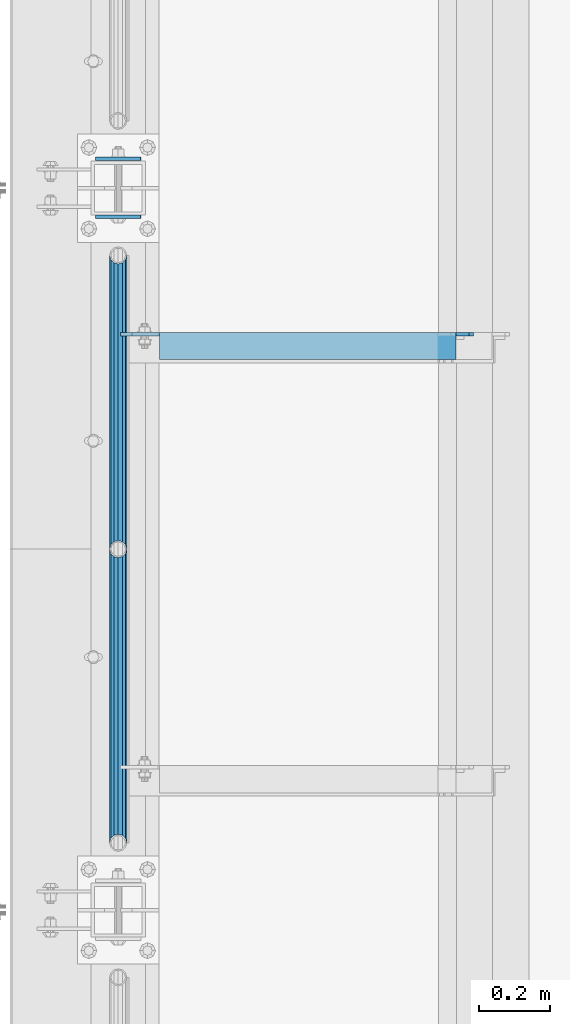
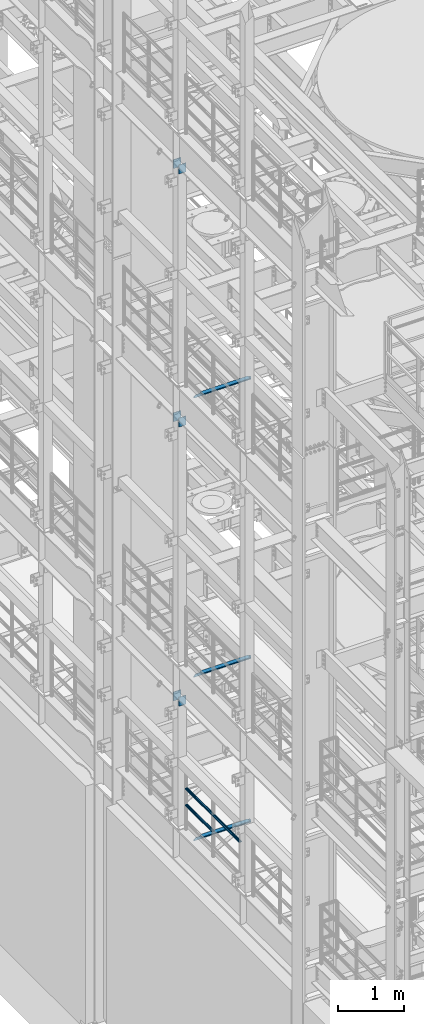
# One storey, part 1229 of 1876: 12 beams, 7 elements without a shape of their own.
"""IFC2X3 building model written with IfcOpenShell, lengths in millimetres."""

from ifc_helpers import new_model, si_unit, frame, origin_with_axes, place, context, subcontext, project, spatial, faceted_brep, material, type_object, element, aggregate, save


model = new_model("IFC2X3")

# Units and contexts
model_context = context("Model", 3, precision=1e-05, world=origin_with_axes())
body_context = subcontext(model_context, "Body", "Model", "MODEL_VIEW")
ifc_project = project(units=[si_unit("LENGTHUNIT", "METRE", prefix="MILLI"), si_unit("AREAUNIT", "SQUARE_METRE"), si_unit("VOLUMEUNIT", "CUBIC_METRE"), si_unit("MASSUNIT", "GRAM", prefix="KILO"), si_unit("TIMEUNIT", "SECOND"), si_unit("PLANEANGLEUNIT", "RADIAN"), si_unit("SOLIDANGLEUNIT", "STERADIAN"), si_unit("THERMODYNAMICTEMPERATUREUNIT", "DEGREE_CELSIUS"), si_unit("LUMINOUSINTENSITYUNIT", "LUMEN")], contexts=[model_context])

# Site, building, storey
site_placement = place(None, origin_with_axes())
site = spatial("IfcSite", under=ifc_project, at=site_placement, CompositionType="ELEMENT")
building_placement = place(site_placement, origin_with_axes())
building = spatial("IfcBuilding", under=site, at=building_placement, Name="Undefined", CompositionType="ELEMENT")
storey_placement = place(building_placement, origin_with_axes())
storey = spatial("IfcBuildingStorey", under=building, at=storey_placement, Name="Undefined", CompositionType="ELEMENT", Elevation=0.0)

# Assembly, beams
assembly_1_placement = place(storey_placement, origin_with_axes())
assembly_1 = element("IfcElementAssembly", 1, at=assembly_1_placement, inside=storey, Name="RAIL", AssemblyPlace="NOTDEFINED", PredefinedType="RIGID_FRAME")
ifc_material_1 = material()
beam_type_1 = type_object("IfcBeamType", Name="PIPE1-1/2SCH40", PredefinedType="NOTDEFINED")
beam_1_placement = place(assembly_1_placement, frame((-1.81898940354586e-12, -1524.0, 5597.525), z_axis=(0.0, 0.0, -1.0), x_axis=(0.0, 1.0, 0.0)))
beam_1 = element("IfcBeam", 2, at=beam_1_placement, type_object=beam_type_1, material=ifc_material_1, Name="RAIL", ObjectType="PIPE1-1/2SCH40", context=body_context, shape_type="Brep", body=[
    faceted_brep([(0.0, 24.1299999999992, 0.0), (12.0650000000064, 20.8971929933177, -12.0649999999987), (12.0650000000064, 20.8971929933177, 12.0649999999987), (12.0650000000064, -20.8971929933177, 12.0649999999987), (12.0650000000064, -20.8971929933177, -12.0649999999987), (0.0, -24.1299999999992, 0.0), (20.8971929933249, -12.0650000000005, 20.8971929933177), (20.8971929933249, -12.0650000000005, 15.8661214311796), (15.2545715621445, -17.7076214311801, 10.2235000000001), (12.5151929933249, -20.4470000000001, 0.0), (15.2545715621445, -17.7076214311801, -10.2235000000001), (20.8971929933249, -12.0650000000005, -15.8661214311796), (20.8971929933249, -12.0650000000005, -20.8971929933177), (24.1300000000063, 0.0, -20.4470000000001), (24.1300000000063, 0.0, -24.130000000001), (21.3906214311868, -10.2235000000001, -17.7076214311819), (21.3906214311868, 10.2235000000001, -17.7076214311819), (20.8971929933249, 12.0650000000005, -15.8661214311796), (20.8971929933249, 12.0650000000005, -20.8971929933177), (15.2545715621445, 17.7076214311801, -10.2235000000001), (12.5151929933249, 20.4470000000001, 0.0), (15.2545715621445, 17.7076214311801, 10.2235000000001), (20.8971929933249, 12.0650000000005, 15.8661214311796), (20.8971929933249, 12.0650000000005, 20.8971929933177), (21.3906214311868, 10.2235000000001, 17.7076214311819), (24.1300000000064, 0.0, 20.4470000000001), (24.1300000000064, 0.0, 24.130000000001), (21.3906214311868, -10.2235000000001, 17.7076214311819), (826.77, 24.1300000000001, 0.0), (814.705, 20.8971929933186, -12.0649999999987), (805.872807006681, 12.0649999999996, -20.8971929933177), (826.77, -24.1300000000001, 0.0), (814.705, -20.8971929933186, -12.0649999999987), (814.705, -20.8971929933186, 12.0649999999987), (805.872807006681, -12.0649999999996, 20.8971929933177), (805.872807006681, -12.0649999999996, -20.8971929933177), (802.640000000001, 0.0, -24.130000000001), (805.379378568819, 10.2235000000001, -17.7076214311819), (802.640000000001, 0.0, -20.4470000000001), (805.872807006683, 12.0649999999996, -15.8661214311796), (805.872807006683, -12.0649999999996, -15.8661214311796), (805.379378568819, -10.2235000000001, -17.7076214311819), (811.515428437862, -17.7076214311801, -10.2235000000001), (814.254807006682, -20.4470000000001, 0.0), (811.515428437862, -17.7076214311801, 10.2235000000001), (805.872807006683, -12.0649999999996, 15.8661214311796), (805.379378568819, -10.2235000000001, 17.7076214311819), (802.640000000001, 0.0, 20.4470000000001), (802.640000000001, 0.0, 24.130000000001), (805.872807006681, 12.0649999999996, 20.8971929933177), (814.705, 20.8971929933186, 12.0649999999987), (805.872807006683, 12.0649999999996, 15.8661214311796), (811.515428437862, 17.7076214311801, 10.2235000000001), (814.254807006682, 20.4470000000001, 0.0), (811.515428437862, 17.7076214311801, -10.2235000000001), (805.379378568819, 10.2235000000001, 17.7076214311819)], [[[0, 1, 2]], [[3, 4, 5]], [[6, 7, 8, 9, 10, 11, 12, 4, 3]], [[13, 14, 12, 11, 15]], [[16, 17, 18, 14, 13]], [[2, 1, 18, 17, 19, 20, 21, 22, 23]], [[23, 22, 24, 25, 26]], [[26, 25, 27, 7, 6]], [[1, 0, 28, 29]], [[18, 1, 29, 30]], [[31, 32, 33]], [[6, 3, 33, 34]], [[3, 5, 31, 33]], [[5, 4, 32, 31]], [[4, 12, 35, 32]], [[12, 14, 36, 35]], [[14, 18, 30, 36]], [[37, 38, 36, 30, 39]], [[40, 35, 36, 38, 41]], [[33, 32, 35, 40, 42, 43, 44, 45, 34]], [[34, 45, 46, 47, 48]], [[26, 6, 34, 48]], [[2, 23, 49, 50]], [[23, 26, 48, 49]], [[0, 2, 50, 28]], [[28, 50, 29]], [[49, 51, 52, 53, 54, 39, 30, 29, 50]], [[48, 47, 55, 51, 49]], [[25, 24, 55, 47]], [[55, 24, 22, 21, 52, 51]], [[21, 20, 53, 52]], [[20, 19, 54, 53]], [[19, 17, 16, 37, 39, 54]], [[16, 13, 38, 37]], [[13, 15, 41, 38]], [[41, 15, 11, 10, 42, 40]], [[10, 9, 43, 42]], [[9, 8, 44, 43]], [[8, 7, 27, 46, 45, 44]], [[27, 25, 47, 46]]]),
])
beam_2_placement = place(assembly_1_placement, frame((-1.81898940354586e-12, -2350.77, 5902.325), z_axis=(0.0, 0.0, -1.0), x_axis=(0.0, 1.0, 0.0)))
beam_2 = element("IfcBeam", 3, at=beam_2_placement, type_object=beam_type_1, material=ifc_material_1, Name="RAIL", ObjectType="PIPE1-1/2SCH40", context=body_context, shape_type="Brep", body=[
    faceted_brep([(0.0, 24.1299999999992, 0.0), (12.0650000000064, 20.8971929933177, -12.0649999999987), (12.0650000000064, 20.8971929933177, 12.0649999999987), (12.0650000000064, -20.8971929933177, 12.0649999999987), (12.0650000000064, -20.8971929933177, -12.0649999999987), (0.0, -24.1299999999992, 0.0), (20.8971929933249, -12.0650000000005, 20.8971929933177), (20.8971929933249, -12.0650000000005, 15.8661214311796), (15.2545715621445, -17.7076214311801, 10.2235000000001), (12.5151929933249, -20.4470000000001, 0.0), (15.2545715621445, -17.7076214311801, -10.2235000000001), (20.8971929933249, -12.0650000000005, -15.8661214311796), (20.8971929933249, -12.0650000000005, -20.8971929933177), (24.1300000000063, 0.0, -20.4470000000001), (24.1300000000063, 0.0, -24.130000000001), (21.3906214311868, -10.2235000000001, -17.7076214311819), (21.3906214311868, 10.2235000000001, -17.7076214311819), (20.8971929933249, 12.0650000000005, -15.8661214311796), (20.8971929933249, 12.0650000000005, -20.8971929933177), (15.2545715621445, 17.7076214311801, -10.2235000000001), (12.5151929933249, 20.4470000000001, 0.0), (15.2545715621445, 17.7076214311801, 10.2235000000001), (20.8971929933249, 12.0650000000005, 15.8661214311796), (20.8971929933249, 12.0650000000005, 20.8971929933177), (21.3906214311868, 10.2235000000001, 17.7076214311819), (24.1300000000064, 0.0, 20.4470000000001), (24.1300000000064, 0.0, 24.130000000001), (21.3906214311868, -10.2235000000001, 17.7076214311819), (826.77, 24.1300000000001, 0.0), (814.705, 20.8971929933186, -12.0649999999987), (805.872807006681, 12.0649999999996, -20.8971929933177), (826.77, -24.1300000000001, 0.0), (814.705, -20.8971929933186, -12.0649999999987), (814.705, -20.8971929933186, 12.0649999999987), (805.872807006681, -12.0649999999996, 20.8971929933177), (805.872807006681, -12.0649999999996, -20.8971929933177), (802.640000000001, 0.0, -24.130000000001), (805.379378568819, 10.2235000000001, -17.7076214311819), (802.640000000001, 0.0, -20.4470000000001), (805.872807006683, 12.0649999999996, -15.8661214311796), (805.872807006683, -12.0649999999996, -15.8661214311796), (805.379378568819, -10.2235000000001, -17.7076214311819), (811.515428437862, -17.7076214311801, -10.2235000000001), (814.254807006682, -20.4470000000001, 0.0), (811.515428437862, -17.7076214311801, 10.2235000000001), (805.872807006683, -12.0649999999996, 15.8661214311796), (805.379378568819, -10.2235000000001, 17.7076214311819), (802.640000000001, 0.0, 20.4470000000001), (802.640000000001, 0.0, 24.130000000001), (805.872807006681, 12.0649999999996, 20.8971929933177), (814.705, 20.8971929933186, 12.0649999999987), (805.872807006683, 12.0649999999996, 15.8661214311796), (811.515428437862, 17.7076214311801, 10.2235000000001), (814.254807006682, 20.4470000000001, 0.0), (811.515428437862, 17.7076214311801, -10.2235000000001), (805.379378568819, 10.2235000000001, 17.7076214311819)], [[[0, 1, 2]], [[3, 4, 5]], [[6, 7, 8, 9, 10, 11, 12, 4, 3]], [[13, 14, 12, 11, 15]], [[16, 17, 18, 14, 13]], [[2, 1, 18, 17, 19, 20, 21, 22, 23]], [[23, 22, 24, 25, 26]], [[26, 25, 27, 7, 6]], [[1, 0, 28, 29]], [[18, 1, 29, 30]], [[31, 32, 33]], [[6, 3, 33, 34]], [[3, 5, 31, 33]], [[5, 4, 32, 31]], [[4, 12, 35, 32]], [[12, 14, 36, 35]], [[14, 18, 30, 36]], [[37, 38, 36, 30, 39]], [[40, 35, 36, 38, 41]], [[33, 32, 35, 40, 42, 43, 44, 45, 34]], [[34, 45, 46, 47, 48]], [[26, 6, 34, 48]], [[2, 23, 49, 50]], [[23, 26, 48, 49]], [[0, 2, 50, 28]], [[28, 50, 29]], [[49, 51, 52, 53, 54, 39, 30, 29, 50]], [[48, 47, 55, 51, 49]], [[25, 24, 55, 47]], [[55, 24, 22, 21, 52, 51]], [[21, 20, 53, 52]], [[20, 19, 54, 53]], [[19, 17, 16, 37, 39, 54]], [[16, 13, 38, 37]], [[13, 15, 41, 38]], [[41, 15, 11, 10, 42, 40]], [[10, 9, 43, 42]], [[9, 8, 44, 43]], [[8, 7, 27, 46, 45, 44]], [[27, 25, 47, 46]]]),
])
beam_3_placement = place(assembly_1_placement, frame((-1.81898940354586e-12, -1524.0, 5902.325), z_axis=(0.0, 0.0, -1.0), x_axis=(0.0, 1.0, 0.0)))
beam_3 = element("IfcBeam", 4, at=beam_3_placement, type_object=beam_type_1, material=ifc_material_1, Name="RAIL", ObjectType="PIPE1-1/2SCH40", context=body_context, shape_type="Brep", body=[
    faceted_brep([(0.0, 24.1299999999992, 0.0), (12.0650000000064, 20.8971929933177, -12.0649999999987), (12.0650000000064, 20.8971929933177, 12.0649999999987), (12.0650000000064, -20.8971929933177, 12.0649999999987), (12.0650000000064, -20.8971929933177, -12.0649999999987), (0.0, -24.1299999999992, 0.0), (20.8971929933249, -12.0650000000005, 20.8971929933177), (20.8971929933249, -12.0650000000005, 15.8661214311796), (15.2545715621445, -17.7076214311801, 10.2235000000001), (12.5151929933249, -20.4470000000001, 0.0), (15.2545715621445, -17.7076214311801, -10.2235000000001), (20.8971929933249, -12.0650000000005, -15.8661214311796), (20.8971929933249, -12.0650000000005, -20.8971929933177), (24.1300000000063, 0.0, -20.4470000000001), (24.1300000000063, 0.0, -24.130000000001), (21.3906214311868, -10.2235000000001, -17.7076214311819), (21.3906214311868, 10.2235000000001, -17.7076214311819), (20.8971929933249, 12.0650000000005, -15.8661214311796), (20.8971929933249, 12.0650000000005, -20.8971929933177), (15.2545715621445, 17.7076214311801, -10.2235000000001), (12.5151929933249, 20.4470000000001, 0.0), (15.2545715621445, 17.7076214311801, 10.2235000000001), (20.8971929933249, 12.0650000000005, 15.8661214311796), (20.8971929933249, 12.0650000000005, 20.8971929933177), (21.3906214311868, 10.2235000000001, 17.7076214311819), (24.1300000000064, 0.0, 20.4470000000001), (24.1300000000064, 0.0, 24.130000000001), (21.3906214311868, -10.2235000000001, 17.7076214311819), (826.77, 24.1300000000001, 0.0), (814.705, 20.8971929933186, -12.0649999999987), (805.872807006681, 12.0649999999996, -20.8971929933177), (826.77, -24.1300000000001, 0.0), (814.705, -20.8971929933186, -12.0649999999987), (814.705, -20.8971929933186, 12.0649999999987), (805.872807006681, -12.0649999999996, 20.8971929933177), (805.872807006681, -12.0649999999996, -20.8971929933177), (802.640000000001, 0.0, -24.130000000001), (805.379378568819, 10.2235000000001, -17.7076214311819), (802.640000000001, 0.0, -20.4470000000001), (805.872807006683, 12.0649999999996, -15.8661214311796), (805.872807006683, -12.0649999999996, -15.8661214311796), (805.379378568819, -10.2235000000001, -17.7076214311819), (811.515428437862, -17.7076214311801, -10.2235000000001), (814.254807006682, -20.4470000000001, 0.0), (811.515428437862, -17.7076214311801, 10.2235000000001), (805.872807006683, -12.0649999999996, 15.8661214311796), (805.379378568819, -10.2235000000001, 17.7076214311819), (802.640000000001, 0.0, 20.4470000000001), (802.640000000001, 0.0, 24.130000000001), (805.872807006681, 12.0649999999996, 20.8971929933177), (814.705, 20.8971929933186, 12.0649999999987), (805.872807006683, 12.0649999999996, 15.8661214311796), (811.515428437862, 17.7076214311801, 10.2235000000001), (814.254807006682, 20.4470000000001, 0.0), (811.515428437862, 17.7076214311801, -10.2235000000001), (805.379378568819, 10.2235000000001, 17.7076214311819)], [[[0, 1, 2]], [[3, 4, 5]], [[6, 7, 8, 9, 10, 11, 12, 4, 3]], [[13, 14, 12, 11, 15]], [[16, 17, 18, 14, 13]], [[2, 1, 18, 17, 19, 20, 21, 22, 23]], [[23, 22, 24, 25, 26]], [[26, 25, 27, 7, 6]], [[1, 0, 28, 29]], [[18, 1, 29, 30]], [[31, 32, 33]], [[6, 3, 33, 34]], [[3, 5, 31, 33]], [[5, 4, 32, 31]], [[4, 12, 35, 32]], [[12, 14, 36, 35]], [[14, 18, 30, 36]], [[37, 38, 36, 30, 39]], [[40, 35, 36, 38, 41]], [[33, 32, 35, 40, 42, 43, 44, 45, 34]], [[34, 45, 46, 47, 48]], [[26, 6, 34, 48]], [[2, 23, 49, 50]], [[23, 26, 48, 49]], [[0, 2, 50, 28]], [[28, 50, 29]], [[49, 51, 52, 53, 54, 39, 30, 29, 50]], [[48, 47, 55, 51, 49]], [[25, 24, 55, 47]], [[55, 24, 22, 21, 52, 51]], [[21, 20, 53, 52]], [[20, 19, 54, 53]], [[19, 17, 16, 37, 39, 54]], [[16, 13, 38, 37]], [[13, 15, 41, 38]], [[41, 15, 11, 10, 42, 40]], [[10, 9, 43, 42]], [[9, 8, 44, 43]], [[8, 7, 27, 46, 45, 44]], [[27, 25, 47, 46]]]),
])
aggregate(assembly_1, [beam_1, beam_2, beam_3])

assembly_2_placement = place(storey_placement, origin_with_axes())
assembly_2 = element("IfcElementAssembly", 5, at=assembly_2_placement, inside=storey, Name="BEAM", AssemblyPlace="NOTDEFINED", PredefinedType="RIGID_FRAME")
ifc_material_2 = material(Name="STEEL/A36")
beam_type_2 = type_object("IfcBeamType", PredefinedType="NOTDEFINED")
beam_4_placement = place(assembly_2_placement, frame((-63.6296757345187, -425.45, 7448.54714244377), z_axis=(5.59490000219896e-05, 0.0, -0.999999998434855), x_axis=(0.999999998434855, 0.0, 5.59490000219868e-05)))
beam_4 = element("IfcBeam", 6, at=beam_4_placement, type_object=beam_type_2, material=ifc_material_2, Name="PLATE", context=body_context, shape_type="Brep", body=[
    faceted_brep([(0.0, 4.76249999999982, -82.5499999999993), (0.0, 4.76249999999982, 82.5499999999993), (127.0, 4.76249999999982, 82.5499999999993), (127.0, 4.76249999999982, -82.5499999999993), (0.0, -4.76249999999982, 82.5499999999993), (127.0, -4.76249999999982, 82.5499999999993), (0.0, -4.76249999999982, -82.5499999999993), (127.0, -4.76249999999982, -82.5499999999993)], [[[0, 1, 2, 3]], [[1, 4, 5, 2]], [[4, 6, 7, 5]], [[6, 0, 3, 7]], [[5, 7, 3, 2]], [[6, 4, 1, 0]]]),
])
beam_5_placement = place(assembly_2_placement, frame((-63.6296757345187, -588.9625, 7448.54714244377), z_axis=(5.59490000219896e-05, 0.0, -0.999999998434855), x_axis=(0.999999998434855, 0.0, 5.59490000219868e-05)))
beam_5 = element("IfcBeam", 7, at=beam_5_placement, type_object=beam_type_2, material=ifc_material_2, Name="PLATE", context=body_context, shape_type="Brep", body=[
    faceted_brep([(0.0, 4.76249999999982, -82.5499999999993), (0.0, 4.76249999999982, 82.5499999999993), (127.0, 4.76249999999982, 82.5499999999993), (127.0, 4.76249999999982, -82.5499999999993), (0.0, -4.76249999999982, 82.5499999999993), (127.0, -4.76249999999982, 82.5499999999993), (0.0, -4.76249999999982, -82.5499999999993), (127.0, -4.76249999999982, -82.5499999999993)], [[[0, 1, 2, 3]], [[1, 4, 5, 2]], [[4, 6, 7, 5]], [[6, 0, 3, 7]], [[5, 7, 3, 2]], [[6, 4, 1, 0]]]),
])
aggregate(assembly_2, [beam_4, beam_5])

assembly_3_placement = place(storey_placement, origin_with_axes())
assembly_3 = element("IfcElementAssembly", 8, at=assembly_3_placement, inside=storey, Name="BEAM", AssemblyPlace="NOTDEFINED", PredefinedType="RIGID_FRAME")
beam_6_placement = place(assembly_3_placement, frame((-63.6315195800257, -425.450000000001, 12604.7488224823), z_axis=(2.95459999824743e-05, 0.0, -0.999999999563517), x_axis=(0.999999999563517, 0.0, 2.95459999828704e-05)))
beam_6 = element("IfcBeam", 9, at=beam_6_placement, type_object=beam_type_2, material=ifc_material_2, Name="PLATE", context=body_context, shape_type="Brep", body=[
    faceted_brep([(0.0, 4.76249999999982, -82.5499999999993), (0.0, 4.76249999999982, 82.5499999999993), (127.0, 4.76249999999982, 82.5499999999993), (127.0, 4.76249999999982, -82.5499999999993), (0.0, -4.76249999999982, 82.5499999999993), (127.0, -4.76249999999982, 82.5499999999993), (0.0, -4.76249999999982, -82.5499999999993), (127.0, -4.76249999999982, -82.5499999999993)], [[[0, 1, 2, 3]], [[1, 4, 5, 2]], [[4, 6, 7, 5]], [[6, 0, 3, 7]], [[5, 7, 3, 2]], [[6, 4, 1, 0]]]),
])
beam_7_placement = place(assembly_3_placement, frame((-63.6315195800257, -588.962500000001, 12604.7488224823), z_axis=(2.95459999824743e-05, 0.0, -0.999999999563517), x_axis=(0.999999999563517, 0.0, 2.95459999828704e-05)))
beam_7 = element("IfcBeam", 10, at=beam_7_placement, type_object=beam_type_2, material=ifc_material_2, Name="PLATE", context=body_context, shape_type="Brep", body=[
    faceted_brep([(0.0, 4.76249999999982, -82.5499999999993), (0.0, 4.76249999999982, 82.5499999999993), (127.0, 4.76249999999982, 82.5499999999993), (127.0, 4.76249999999982, -82.5499999999993), (0.0, -4.76249999999982, 82.5499999999993), (127.0, -4.76249999999982, 82.5499999999993), (0.0, -4.76249999999982, -82.5499999999993), (127.0, -4.76249999999982, -82.5499999999993)], [[[0, 1, 2, 3]], [[1, 4, 5, 2]], [[4, 6, 7, 5]], [[6, 0, 3, 7]], [[5, 7, 3, 2]], [[6, 4, 1, 0]]]),
])
aggregate(assembly_3, [beam_6, beam_7])

assembly_4_placement = place(storey_placement, origin_with_axes())
assembly_4 = element("IfcElementAssembly", 11, at=assembly_4_placement, inside=storey, Name="BEAM", AssemblyPlace="NOTDEFINED", PredefinedType="RIGID_FRAME")
beam_8_placement = place(assembly_4_placement, frame((-63.5, -425.450000000001, 17278.35), z_axis=(0.0, 0.0, -1.0), x_axis=(1.0, 0.0, 0.0)))
beam_8 = element("IfcBeam", 12, at=beam_8_placement, type_object=beam_type_2, material=ifc_material_2, Name="PLATE", context=body_context, shape_type="Brep", body=[
    faceted_brep([(0.0, 4.76249999999982, -82.5499999999993), (0.0, 4.76249999999982, 82.5499999999993), (127.0, 4.76249999999982, 82.5499999999993), (127.0, 4.76249999999982, -82.5499999999993), (0.0, -4.76249999999982, 82.5499999999993), (127.0, -4.76249999999982, 82.5499999999993), (0.0, -4.76249999999982, -82.5499999999993), (127.0, -4.76249999999982, -82.5499999999993)], [[[0, 1, 2, 3]], [[1, 4, 5, 2]], [[4, 6, 7, 5]], [[6, 0, 3, 7]], [[5, 7, 3, 2]], [[6, 4, 1, 0]]]),
])
beam_9_placement = place(assembly_4_placement, frame((-63.5, -588.962500000001, 17278.35), z_axis=(0.0, 0.0, -1.0), x_axis=(1.0, 0.0, 0.0)))
beam_9 = element("IfcBeam", 13, at=beam_9_placement, type_object=beam_type_2, material=ifc_material_2, Name="PLATE", context=body_context, shape_type="Brep", body=[
    faceted_brep([(0.0, 4.76249999999982, -82.5499999999993), (0.0, 4.76249999999982, 82.5499999999993), (127.0, 4.76249999999982, 82.5499999999993), (127.0, 4.76249999999982, -82.5499999999993), (0.0, -4.76249999999982, 82.5499999999993), (127.0, -4.76249999999982, 82.5499999999993), (0.0, -4.76249999999982, -82.5499999999993), (127.0, -4.76249999999982, -82.5499999999993)], [[[0, 1, 2, 3]], [[1, 4, 5, 2]], [[4, 6, 7, 5]], [[6, 0, 3, 7]], [[5, 7, 3, 2]], [[6, 4, 1, 0]]]),
])
aggregate(assembly_4, [beam_8, beam_9])

# Assembly, beam
assembly_5_placement = place(storey_placement, origin_with_axes())
assembly_5 = element("IfcElementAssembly", 14, at=assembly_5_placement, inside=storey, Name="ANGLE", AssemblyPlace="NOTDEFINED", PredefinedType="RIGID_FRAME")
beam_type_3 = type_object("IfcBeamType", Name="L3X3X3/8", PredefinedType="NOTDEFINED")
beam_10_placement = place(assembly_5_placement, frame((0.0, -952.500000000001, 8115.3), z_axis=(0.0, -1.0, 0.0), x_axis=(1.0, 0.0, 0.0)))
beam_10 = element("IfcBeam", 15, at=beam_10_placement, type_object=beam_type_3, material=ifc_material_2, Name="ANGLE", ObjectType="L3X3X3/8", context=body_context, shape_type="Brep", body=[
    faceted_brep([(115.886999817316, 28.5750000000007, 38.0999999999999), (115.886999817316, 38.0999999999985, 38.0999999999999), (115.886998826692, 38.0999999999985, -38.0999999999999), (115.88699882669, 12.699999237062, -38.0999999999999), (115.886998950515, 12.699999237062, -28.5749999999998), (115.88699895052, 28.5750000000007, -28.5749999999998), (38.8937432114558, 12.699999237062, -38.0999999999999), (38.8937433352807, 12.699999237062, -28.5749999999998), (7.14374321145577, -19.050000762938, -38.0999999999999), (7.14374333528067, -19.050000762938, -28.5749999999998), (7.1437499954859, -38.0999999999985, -38.0999999999999), (7.1437499954859, -38.0999999999985, -28.5749999999998), (1000.12500242412, 15.8750003814712, -28.5749999999998), (987.425002614851, 28.5749999999998, -28.5749999999998), (950.913000303442, 28.5749999999998, -28.5749999999998), (1000.12500001551, -38.1000000000004, -28.5749999999998), (1000.12500242412, 3.17500152588036, -28.5749999999998), (950.913001170238, 28.5749999999998, 38.0999999999999), (950.913001170238, 38.1000000000004, 38.0999999999999), (950.913000179614, 38.1000000000004, -38.0999999999999), (950.913000366403, 28.5750001907363, -38.0999999999999), (987.425002357675, 28.5750001907363, -38.0999999999999), (1000.12500216694, 15.8750003814712, -38.0999999999999), (1000.12500216694, 3.17500152588036, -38.0999999999999), (1000.12500001551, -38.1000000000004, -38.0999999999999)], [[[0, 1, 2, 3, 4, 5]], [[4, 3, 6, 7]], [[7, 6, 8, 9]], [[8, 10, 11, 9]], [[12, 13, 14, 5, 4, 7, 9, 11, 15, 16]], [[0, 5, 14, 17]], [[1, 0, 17, 18]], [[2, 1, 18, 19]], [[17, 14, 20, 19, 18]], [[13, 21, 20, 14]], [[12, 22, 21, 13]], [[16, 23, 22, 12]], [[10, 8, 6, 3, 2, 19, 20, 21, 22, 23, 24]], [[11, 10, 24, 15]], [[23, 16, 15, 24]]]),
])
aggregate(assembly_5, [beam_10])

assembly_6_placement = place(storey_placement, origin_with_axes())
assembly_6 = element("IfcElementAssembly", 16, at=assembly_6_placement, inside=storey, Name="ANGLE", AssemblyPlace="NOTDEFINED", PredefinedType="RIGID_FRAME")
beam_11_placement = place(assembly_6_placement, frame((0.0, -952.500000000001, 5092.7), z_axis=(0.0, -1.0, 0.0), x_axis=(1.0, 0.0, 0.0)))
beam_11 = element("IfcBeam", 17, at=beam_11_placement, type_object=beam_type_3, material=ifc_material_2, Name="ANGLE", ObjectType="L3X3X3/8", context=body_context, shape_type="Brep", body=[
    faceted_brep([(115.886999817316, 28.5750000000007, 38.0999999999999), (115.886999817316, 38.0999999999985, 38.0999999999999), (115.886998826692, 38.0999999999985, -38.0999999999999), (115.88699882669, 12.699999237062, -38.0999999999999), (115.886998950515, 12.699999237062, -28.5749999999998), (115.88699895052, 28.5750000000007, -28.5749999999998), (38.8937432114558, 12.699999237062, -38.0999999999999), (38.8937433352807, 12.699999237062, -28.5749999999998), (7.14374321145577, -19.050000762938, -38.0999999999999), (7.14374333528067, -19.050000762938, -28.5749999999998), (7.1437499954859, -38.0999999999985, -38.0999999999999), (7.1437499954859, -38.0999999999985, -28.5749999999998), (1000.12500242412, 15.8750003814712, -28.5749999999998), (987.425002614851, 28.5749999999998, -28.5749999999998), (950.913000303442, 28.5749999999998, -28.5749999999998), (1000.12500001551, -38.1000000000004, -28.5749999999998), (1000.12500242412, 3.17500152588036, -28.5749999999998), (950.913001170238, 28.5749999999998, 38.0999999999999), (950.913001170238, 38.1000000000004, 38.0999999999999), (950.913000179614, 38.1000000000004, -38.0999999999999), (950.913000366403, 28.5750001907363, -38.0999999999999), (987.425002357675, 28.5750001907363, -38.0999999999999), (1000.12500216694, 15.8750003814712, -38.0999999999999), (1000.12500216694, 3.17500152588036, -38.0999999999999), (1000.12500001551, -38.1000000000004, -38.0999999999999)], [[[0, 1, 2, 3, 4, 5]], [[4, 3, 6, 7]], [[7, 6, 8, 9]], [[8, 10, 11, 9]], [[12, 13, 14, 5, 4, 7, 9, 11, 15, 16]], [[0, 5, 14, 17]], [[1, 0, 17, 18]], [[2, 1, 18, 19]], [[17, 14, 20, 19, 18]], [[13, 21, 20, 14]], [[12, 22, 21, 13]], [[16, 23, 22, 12]], [[10, 8, 6, 3, 2, 19, 20, 21, 22, 23, 24]], [[11, 10, 24, 15]], [[23, 16, 15, 24]]]),
])
aggregate(assembly_6, [beam_11])

assembly_7_placement = place(storey_placement, origin_with_axes())
assembly_7 = element("IfcElementAssembly", 18, at=assembly_7_placement, inside=storey, Name="ANGLE", AssemblyPlace="NOTDEFINED", PredefinedType="RIGID_FRAME")
beam_12_placement = place(assembly_7_placement, frame((-1.57146639077011e-08, -952.499999999996, 13271.5), z_axis=(0.0, -1.0, 0.0), x_axis=(1.0, 0.0, 0.0)))
beam_12 = element("IfcBeam", 19, at=beam_12_placement, type_object=beam_type_3, material=ifc_material_2, Name="ANGLE", ObjectType="L3X3X3/8", context=body_context, shape_type="Brep", body=[
    faceted_brep([(115.886999817316, 28.5750000000007, 38.0999999999999), (115.886999817316, 38.0999999999985, 38.0999999999999), (115.886998826692, 38.0999999999985, -38.0999999999999), (115.88699882669, 12.699999237062, -38.0999999999999), (115.886998950515, 12.699999237062, -28.5749999999998), (115.88699895052, 28.5750000000007, -28.5749999999998), (38.8937432114558, 12.699999237062, -38.0999999999999), (38.8937433352807, 12.699999237062, -28.5749999999998), (7.14374321145577, -19.050000762938, -38.0999999999999), (7.14374333528067, -19.050000762938, -28.5749999999998), (7.1437499954859, -38.0999999999985, -38.0999999999999), (7.1437499954859, -38.0999999999985, -28.5749999999998), (1000.12500243948, 14.2880004882809, -28.5749999999998), (987.425002630213, 26.988000297546, -28.5749999999998), (950.913000638941, 26.988000297546, -28.5749999999998), (950.913000303442, 28.5749999999998, -28.5749999999998), (1000.12500001551, -38.1000000000004, -28.5749999999998), (1000.12500243948, 1.58799972534143, -28.5749999999998), (950.913001170238, 28.5749999999998, 38.0999999999999), (950.913001170238, 38.1000000000004, 38.0999999999999), (950.913000179614, 38.1000000000004, -38.0999999999999), (950.913000381765, 26.988000297546, -38.0999999999999), (987.425002373037, 26.988000297546, -38.0999999999999), (1000.1250021823, 14.2880004882809, -38.0999999999999), (1000.1250021823, 1.58799972534143, -38.0999999999999), (1000.12500001551, -38.1000000000004, -38.0999999999999)], [[[0, 1, 2, 3, 4, 5]], [[4, 3, 6, 7]], [[7, 6, 8, 9]], [[8, 10, 11, 9]], [[12, 13, 14, 15, 5, 4, 7, 9, 11, 16, 17]], [[0, 5, 15, 18]], [[1, 0, 18, 19]], [[2, 1, 19, 20]], [[18, 15, 14, 21, 20, 19]], [[13, 22, 21, 14]], [[12, 23, 22, 13]], [[17, 24, 23, 12]], [[10, 8, 6, 3, 2, 20, 21, 22, 23, 24, 25]], [[11, 10, 25, 16]], [[24, 17, 16, 25]]]),
])
aggregate(assembly_7, [beam_12])

save(model, "model.ifc")
